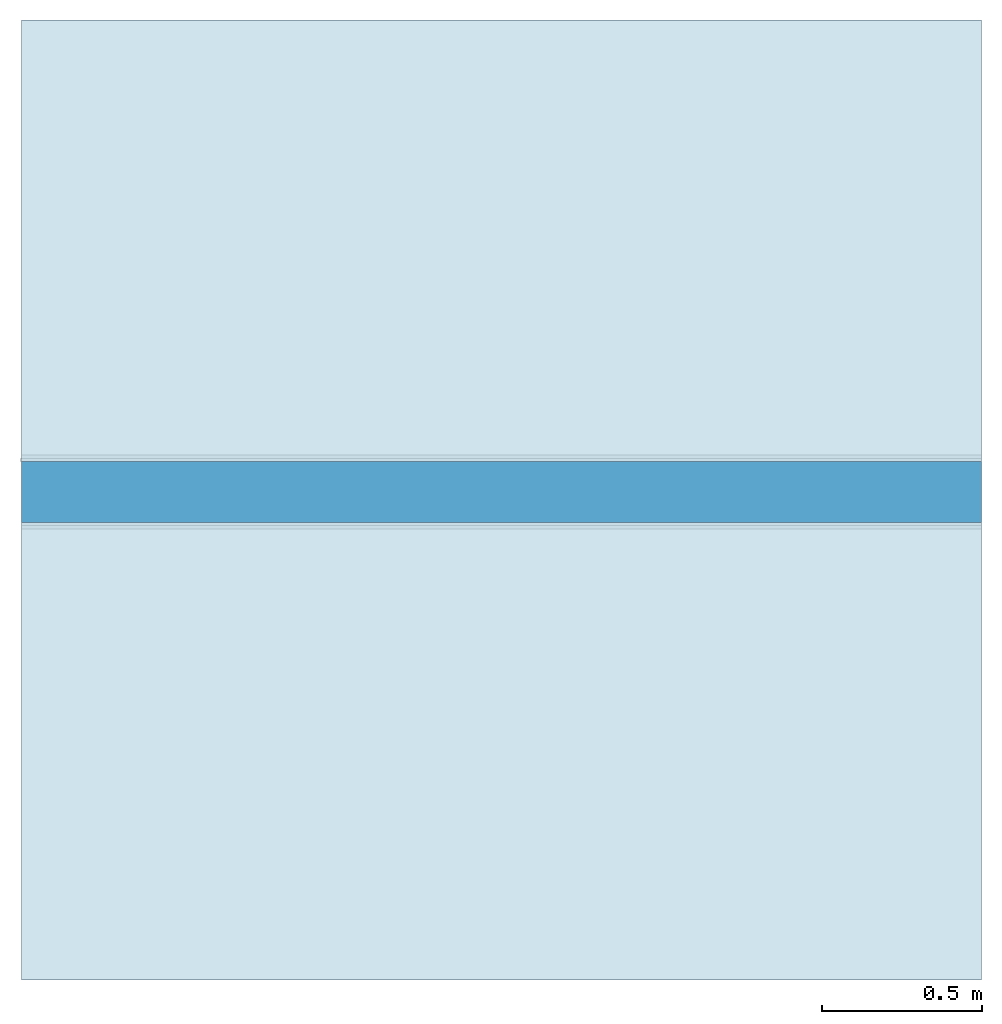
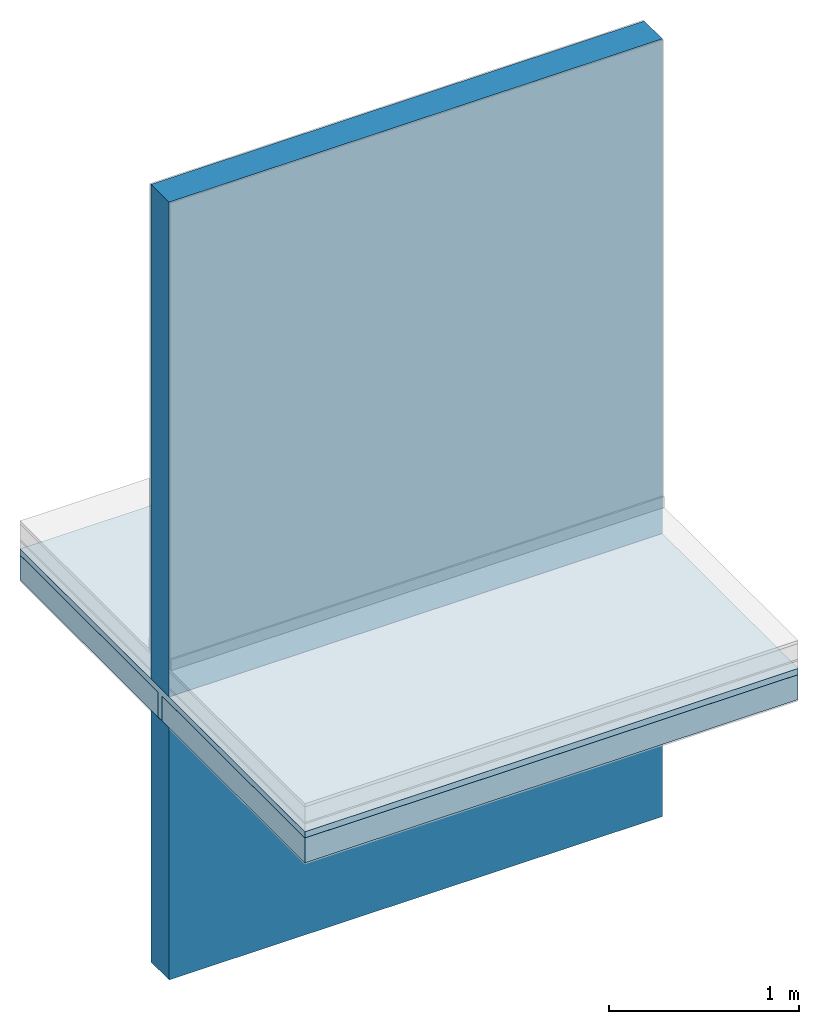
# One storey, part 1 of 2: 3 slabs, 2 walls.
"""IFC4 building model written with IfcOpenShell, lengths in centimetres."""

from ifc_helpers import new_model, si_unit, frame, origin_with_axes, place, context, subcontext, project, spatial, polygons, source, transform, mapped, element, save


model = new_model("IFC4")

# Units and contexts
model_context = context("Model", 3, precision=1e-05, world=origin_with_axes())
plan_context = context("Plan", 2, precision=1e-05, world=origin_with_axes())
body_context = subcontext(model_context, "Body", "Model", "MODEL_VIEW")
ifc_project = project(units=[si_unit("LENGTHUNIT", "METRE", prefix="CENTI"), si_unit("AREAUNIT", "SQUARE_METRE", prefix="CENTI"), si_unit("VOLUMEUNIT", "CUBIC_METRE", prefix="CENTI")], contexts=[model_context, plan_context])

# Site, building, storey
site_placement = place(None, frame((1288.70067596436, 2573.25820922852, 0.0), z_axis=(0.0, 0.0, 1.0), x_axis=(1.0, 0.0, 0.0)))
site = spatial("IfcSite", under=ifc_project, at=site_placement, CompositionType="ELEMENT")
building_placement = place(site_placement, origin_with_axes())
building = spatial("IfcBuilding", under=site, at=building_placement, Name="Default", CompositionType="ELEMENT")
storey_placement = place(building_placement, frame((0.0, 0.0, 1.9145924429198e-09), z_axis=(0.0, 0.0, 1.0), x_axis=(1.0, 0.0, 0.0)))
storey = spatial("IfcBuildingStorey", under=building, at=storey_placement, Name="0", CompositionType="ELEMENT")

# Slabs
shared_shape_1 = source(origin_with_axes(), body_context, "Body", "Tessellation", [
    polygons([(485.905364990234, 411.556915283203, -38.0), (485.905364990234, 411.556915283203, -22.0), (185.905349731445, 411.556915283203, -38.0), (185.905349731445, 411.556915283203, -22.0), (185.905349731445, 266.056915283203, -38.0), (185.905349731445, 266.056915283203, -22.0), (485.905364990234, 266.056915283203, -38.0), (485.905364990234, 266.056915283203, -22.0)], [[[8, 6, 5, 7]], [[2, 8, 7, 1]], [[1, 7, 5, 3]], [[6, 8, 2, 4]], [[4, 2, 1, 3]], [[6, 4, 3, 5]]]),
])
slab_1_placement = place(storey_placement, frame((9.5367431640625e-05, 0.00019073486328125, -1.9145924429198e-09), z_axis=(0.0, 0.0, 1.0), x_axis=(1.0, 0.0, 0.0)))
element("IfcSlab", 1, at=slab_1_placement, inside=storey, PredefinedType="FLOOR", context=body_context, shape_type="MappedRepresentation", body=[
    mapped(shared_shape_1, transform((0.0, 0.0, 0.0), x_axis=(1.0, 0.0, 0.0), y_axis=(0.0, 1.0, 0.0), z_axis=(0.0, 0.0, 1.0), scale=1.0)),
])
shared_shape_2 = source(origin_with_axes(), body_context, "Body", "Tessellation", [
    polygons([(185.905349731445, 266.056915283203, -38.0), (485.905364990234, 266.056915283203, -38.0), (185.905349731445, 262.056915283203, -38.0), (485.905364990234, 262.056915283203, -38.0), (185.905349731445, 262.056915283203, -22.0), (485.905364990234, 262.056915283203, -22.0), (185.905349731445, 111.556922912598, -22.0), (485.905364990234, 111.556922912598, -22.0), (185.905349731445, 111.556922912598, -18.0), (485.905364990234, 111.556922912598, -18.0), (185.905349731445, 411.556915283203, -18.0), (485.905364990234, 411.556915283203, -18.0), (185.905349731445, 411.556915283203, -22.0), (485.905364990234, 411.556915283203, -22.0), (185.905349731445, 266.056915283203, -22.0), (485.905364990234, 266.056915283203, -22.0)], [[[4, 6, 5, 3]], [[6, 8, 7, 5]], [[8, 10, 9, 7]], [[10, 12, 11, 9]], [[12, 14, 13, 11]], [[14, 16, 15, 13]], [[16, 2, 1, 15]], [[3, 5, 15, 1]], [[5, 7, 9]], [[6, 4, 2, 16]], [[11, 13, 15]], [[9, 11, 15]], [[9, 15, 5]], [[10, 8, 6]], [[16, 14, 12]], [[16, 12, 10]], [[6, 16, 10]], [[2, 4, 3, 1]]]),
])
slab_2_placement = place(storey_placement, frame((9.5367431640625e-05, 0.00019073486328125, -1.9145924429198e-09), z_axis=(0.0, 0.0, 1.0), x_axis=(1.0, 0.0, 0.0)))
element("IfcSlab", 2, at=slab_2_placement, inside=storey, Name="Dalle de compression", PredefinedType="FLOOR", context=body_context, shape_type="MappedRepresentation", body=[
    mapped(shared_shape_2, transform((0.0, 0.0, 0.0), x_axis=(1.0, 0.0, 0.0), y_axis=(0.0, 1.0, 0.0), z_axis=(0.0, 0.0, 1.0), scale=1.0)),
])
shared_shape_3 = source(origin_with_axes(), body_context, "Body", "Tessellation", [
    polygons([(485.905364990234, 262.056915283203, -38.0), (485.905364990234, 262.056915283203, -22.0), (185.905349731445, 262.056915283203, -38.0), (185.905349731445, 262.056915283203, -22.0), (185.905349731445, 111.556922912598, -38.0), (185.905349731445, 111.556922912598, -22.0), (485.905364990234, 111.556922912598, -38.0), (485.905364990234, 111.556922912598, -22.0)], [[[8, 6, 5, 7]], [[2, 8, 7, 1]], [[1, 7, 5, 3]], [[6, 8, 2, 4]], [[4, 2, 1, 3]], [[6, 4, 3, 5]]]),
])
slab_3_placement = place(storey_placement, frame((9.5367431640625e-05, 0.00019073486328125, -1.9145924429198e-09), z_axis=(0.0, 0.0, 1.0), x_axis=(1.0, 0.0, 0.0)))
element("IfcSlab", 3, at=slab_3_placement, inside=storey, PredefinedType="FLOOR", context=body_context, shape_type="MappedRepresentation", body=[
    mapped(shared_shape_3, transform((0.0, 0.0, 0.0), x_axis=(1.0, 0.0, 0.0), y_axis=(0.0, 1.0, 0.0), z_axis=(0.0, 0.0, 1.0), scale=1.0)),
])

# Walls
shared_shape_4 = source(origin_with_axes(), body_context, "Body", "Tessellation", [
    polygons([(300.0, -9.5, 0.0), (300.0, -9.5, 318.0), (300.0, 9.5, 0.0), (300.0, 9.5, 318.0), (0.0, 9.5, 0.0), (0.0, 9.5, 318.0), (0.0, -9.5, 0.0), (0.0, -9.5, 318.0)], [[[8, 6, 5, 7]], [[2, 8, 7, 1]], [[1, 7, 5, 3]], [[6, 8, 2, 4]], [[4, 2, 1, 3]], [[6, 4, 3, 5]]]),
])
wall_1_placement = place(storey_placement, frame((185.905361175537, 264.056968688965, -18.0000007152557), z_axis=(0.0, 0.0, 1.0), x_axis=(1.0, 0.0, 0.0)))
element("IfcWall", 4, at=wall_1_placement, inside=storey, PredefinedType="SOLIDWALL", context=body_context, shape_type="MappedRepresentation", body=[
    mapped(shared_shape_4, transform((0.0, 0.0, 0.0), x_axis=(1.0, 0.0, 0.0), y_axis=(0.0, 1.0, 0.0), z_axis=(0.0, 0.0, 1.0), scale=1.0)),
])
shared_shape_5 = source(origin_with_axes(), body_context, "Body", "Tessellation", [
    polygons([(300.0, -9.5, 0.0), (300.0, -9.5, 162.0), (300.0, 9.5, 0.0), (300.0, 9.5, 162.0), (0.0, 9.5, 0.0), (0.0, 9.5, 162.0), (0.0, -9.5, 0.0), (0.0, -9.5, 162.0)], [[[8, 6, 5, 7]], [[2, 8, 7, 1]], [[1, 7, 5, 3]], [[6, 8, 2, 4]], [[4, 2, 1, 3]], [[6, 4, 3, 5]]]),
])
wall_2_placement = place(storey_placement, frame((185.905361175537, 264.056968688965, -200.0), z_axis=(0.0, 0.0, 1.0), x_axis=(1.0, 0.0, 0.0)))
element("IfcWall", 5, at=wall_2_placement, inside=storey, PredefinedType="SOLIDWALL", context=body_context, shape_type="MappedRepresentation", body=[
    mapped(shared_shape_5, transform((0.0, 0.0, 0.0), x_axis=(1.0, 0.0, 0.0), y_axis=(0.0, 1.0, 0.0), z_axis=(0.0, 0.0, 1.0), scale=1.0)),
])

save(model, "model.ifc")
